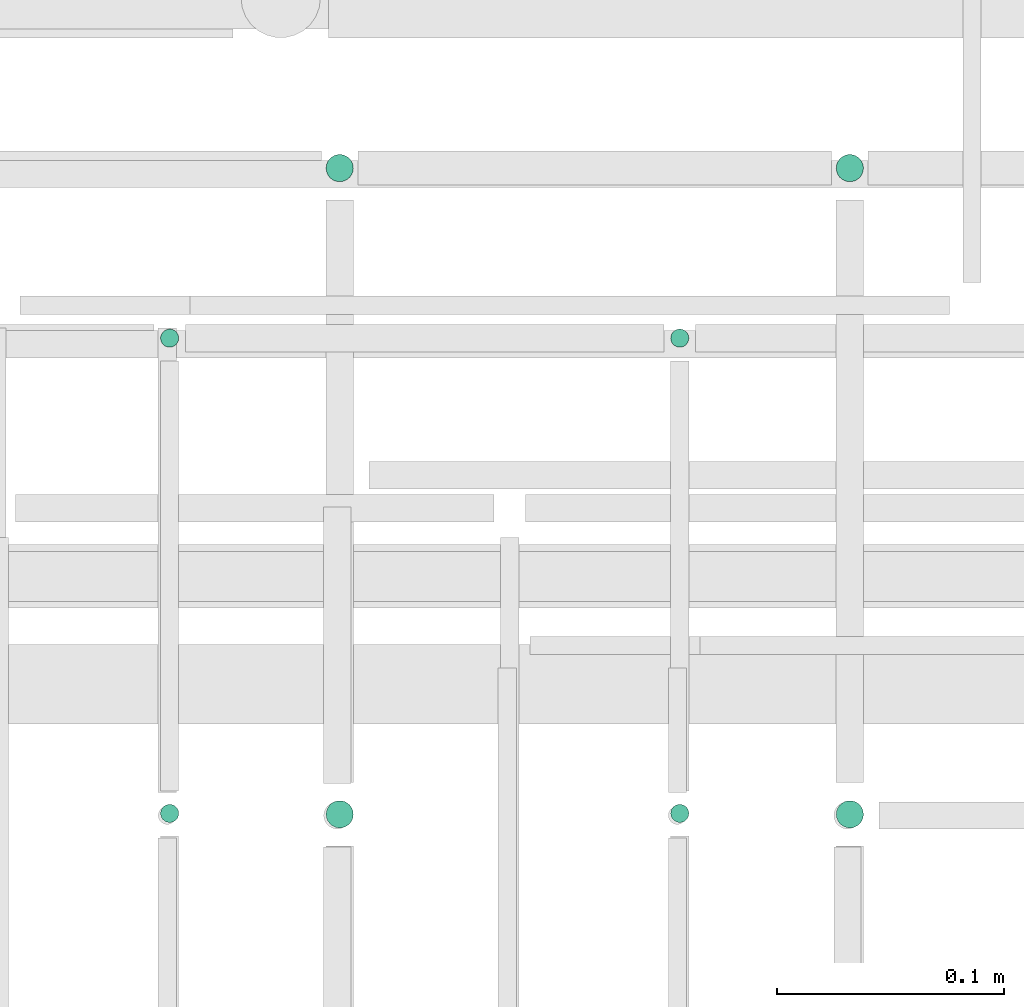
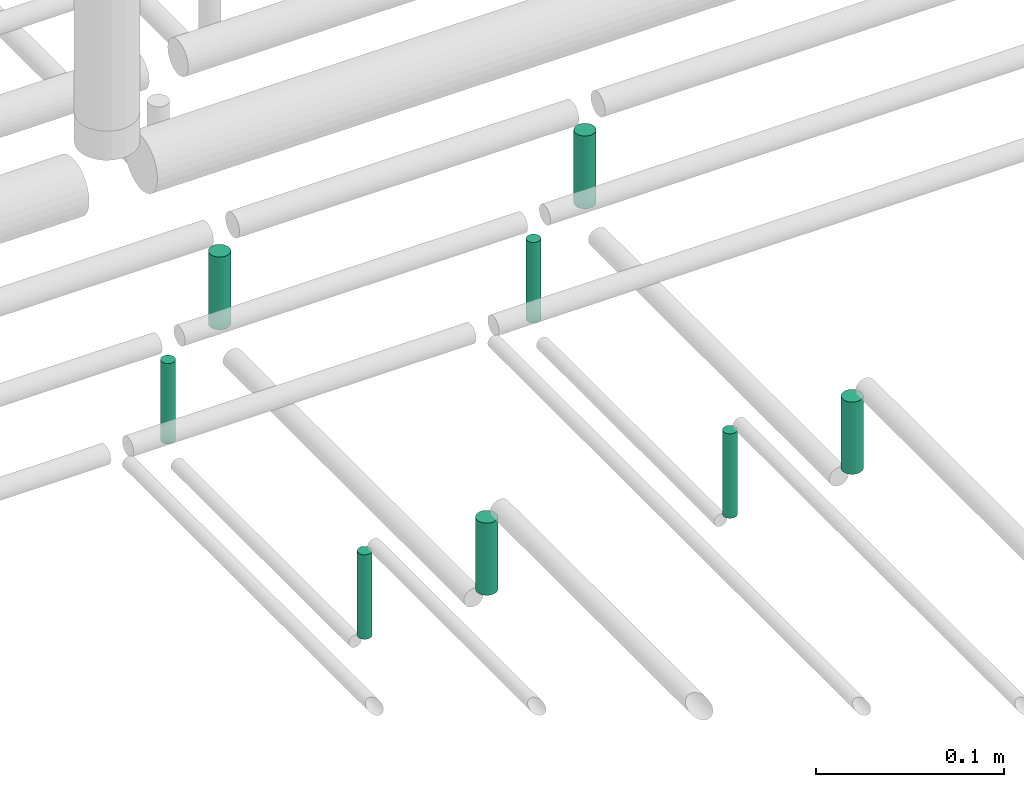
# One storey, part 293 of 331: 8 flow segments.
"""IFC2X3 building model written with IfcOpenShell, lengths in millimetres."""

from ifc_helpers import new_model, entity, si_unit, converted_unit, derived_unit, direction, frame, frame_2d, origin, origin_2d_with_axis, place, context, subcontext, project, spatial, circle, extrude, type_object, element, save


model = new_model("IFC2X3")

# Units and contexts
model_context = context("Model", 3, precision=0.01, world=origin(), true_north=direction((6.12303176911189e-17, 1.0)))
body_context = subcontext(model_context, "Body", "Model", "MODEL_VIEW")
ifc_project = project(units=[si_unit("LENGTHUNIT", "METRE", prefix="MILLI"), si_unit("AREAUNIT", "SQUARE_METRE"), si_unit("VOLUMEUNIT", "CUBIC_METRE"), converted_unit("PLANEANGLEUNIT", "DEGREE", entity("IfcRatioMeasure", 0.0174532925199433), si_unit("PLANEANGLEUNIT", "RADIAN"), dimensions=[0, 0, 0, 0, 0, 0, 0]), si_unit("MASSUNIT", "GRAM", prefix="KILO"), derived_unit("MASSDENSITYUNIT", [(si_unit("MASSUNIT", "GRAM", prefix="KILO"), 1), (si_unit("LENGTHUNIT", "METRE"), -3)]), derived_unit("MOMENTOFINERTIAUNIT", [(si_unit("LENGTHUNIT", "METRE"), 4)]), si_unit("TIMEUNIT", "SECOND"), si_unit("FREQUENCYUNIT", "HERTZ"), si_unit("THERMODYNAMICTEMPERATUREUNIT", "DEGREE_CELSIUS"), derived_unit("THERMALTRANSMITTANCEUNIT", [(si_unit("MASSUNIT", "GRAM", prefix="KILO"), 1), (si_unit("THERMODYNAMICTEMPERATUREUNIT", "KELVIN"), -1), (si_unit("TIMEUNIT", "SECOND"), -3)]), derived_unit("VOLUMETRICFLOWRATEUNIT", [(si_unit("LENGTHUNIT", "METRE"), 3), (si_unit("TIMEUNIT", "SECOND"), -1)]), derived_unit("MASSFLOWRATEUNIT", [(si_unit("MASSUNIT", "GRAM", prefix="KILO"), 1), (si_unit("TIMEUNIT", "SECOND"), -1)]), derived_unit("ROTATIONALFREQUENCYUNIT", [(si_unit("TIMEUNIT", "SECOND"), -1)]), si_unit("ELECTRICCURRENTUNIT", "AMPERE"), si_unit("ELECTRICVOLTAGEUNIT", "VOLT"), si_unit("POWERUNIT", "WATT"), si_unit("FORCEUNIT", "NEWTON", prefix="KILO"), si_unit("ILLUMINANCEUNIT", "LUX"), si_unit("LUMINOUSFLUXUNIT", "LUMEN"), si_unit("LUMINOUSINTENSITYUNIT", "CANDELA"), derived_unit("USERDEFINED", [(si_unit("MASSUNIT", "GRAM", prefix="KILO"), -1), (si_unit("LENGTHUNIT", "METRE"), -2), (si_unit("TIMEUNIT", "SECOND"), 3), (si_unit("LUMINOUSFLUXUNIT", "LUMEN"), 1)]), derived_unit("LINEARVELOCITYUNIT", [(si_unit("LENGTHUNIT", "METRE"), 1), (si_unit("TIMEUNIT", "SECOND"), -1)]), si_unit("PRESSUREUNIT", "PASCAL"), derived_unit("USERDEFINED", [(si_unit("LENGTHUNIT", "METRE"), -2), (si_unit("MASSUNIT", "GRAM", prefix="KILO"), 1), (si_unit("TIMEUNIT", "SECOND"), -2)]), derived_unit("LINEARFORCEUNIT", [(si_unit("MASSUNIT", "GRAM", prefix="KILO"), 1), (si_unit("LENGTHUNIT", "METRE"), 1), (si_unit("TIMEUNIT", "SECOND"), -2), (si_unit("LENGTHUNIT", "METRE"), -1)]), derived_unit("PLANARFORCEUNIT", [(si_unit("MASSUNIT", "GRAM", prefix="KILO"), 1), (si_unit("LENGTHUNIT", "METRE"), 1), (si_unit("TIMEUNIT", "SECOND"), -2), (si_unit("LENGTHUNIT", "METRE"), -2)])], contexts=[model_context])

# Site, building, storey
site_placement = place(None, frame((0.0, -0.00077364408347762, 0.0)))
site = spatial("IfcSite", under=ifc_project, at=site_placement, CompositionType="ELEMENT")
building_placement = place(site_placement, origin())
building = spatial("IfcBuilding", under=site, at=building_placement, CompositionType="ELEMENT")
storey_placement = place(building_placement, origin())
storey = spatial("IfcBuildingStorey", under=building, at=storey_placement, CompositionType="ELEMENT", Elevation=0.0)

# Flow segments
pipe_segment_type = type_object("IfcPipeSegmentType", PredefinedType="NOTDEFINED")
flow_segment_1_placement = place(storey_placement, frame((62165.5225183915, 8085.4146716134, 14485.0)))
element("IfcFlowSegment", 1, at=flow_segment_1_placement, inside=storey, type_object=pipe_segment_type, context=body_context, shape_type="SweptSolid", body=[
    extrude(circle(Radius=4.0, at=frame_2d((0.0, 1.08286712929839e-12), x_axis=(1.0, 0.0))), frame((5.59527223591499, 5.59527223591716, 0.0), z_axis=(0.0, 0.0, 1.0), x_axis=(-1.0, 0.0, 0.0)), (0.0, 0.0, 1.0), 55.0000000000243),
])
flow_segment_2_placement = place(storey_placement, frame((61940.5225183915, 8085.4146716134, 14485.0)))
element("IfcFlowSegment", 2, at=flow_segment_2_placement, inside=storey, type_object=pipe_segment_type, context=body_context, shape_type="SweptSolid", body=[
    extrude(circle(Radius=4.0, at=frame_2d((0.0, 1.08286712929839e-12), x_axis=(1.0, 0.0))), frame((5.59527223591499, 5.59527223591716, 0.0), z_axis=(0.0, 0.0, 1.0), x_axis=(-1.0, 0.0, 0.0)), (0.0, 0.0, 1.0), 55.0000000000178),
])
flow_segment_3_placement = place(storey_placement, frame((62238.5225183915, 8368.02529159144, 14489.0)))
element("IfcFlowSegment", 3, at=flow_segment_3_placement, inside=storey, type_object=pipe_segment_type, context=body_context, shape_type="SweptSolid", body=[
    extrude(circle(Radius=6.0, at=frame_2d((0.0, -1.08286712929839e-12), x_axis=(1.0, 0.0))), frame((7.59527223591454, 7.5952722359167, 0.0)), (0.0, 0.0, 1.0), 47.3874126245895),
])
flow_segment_4_placement = place(storey_placement, frame((62238.5225183915, 8083.02529159146, 14489.0)))
element("IfcFlowSegment", 4, at=flow_segment_4_placement, inside=storey, type_object=pipe_segment_type, context=body_context, shape_type="SweptSolid", body=[
    extrude(circle(Radius=6.0, at=frame_2d((0.0, -1.08286712929839e-12), x_axis=(1.0, 0.0))), frame((7.59527223591454, 7.59527223591454, 0.0), z_axis=(0.0, 0.0, 1.0), x_axis=(-1.0, 0.0, 0.0)), (0.0, 0.0, 1.0), 47.0000000000066),
])
flow_segment_5_placement = place(storey_placement, frame((62013.5225183915, 8083.02529159144, 14489.0)))
element("IfcFlowSegment", 5, at=flow_segment_5_placement, inside=storey, type_object=pipe_segment_type, context=body_context, shape_type="SweptSolid", body=[
    extrude(circle(Radius=6.0, at=origin_2d_with_axis()), frame((7.59527223591454, 7.59527223591562, 0.0), z_axis=(0.0, 0.0, 1.0), x_axis=(-1.0, 0.0, 0.0)), (0.0, 0.0, 1.0), 47.000000000024),
])
flow_segment_6_placement = place(storey_placement, frame((62165.5214460933, 8295.02529159145, 14484.9999156955)))
element("IfcFlowSegment", 6, at=flow_segment_6_placement, inside=storey, type_object=pipe_segment_type, context=body_context, shape_type="SweptSolid", body=[
    extrude(circle(Radius=4.0, at=origin_2d_with_axis()), frame((5.59637589690863, 5.59527223591607, 8.43044372913937e-05)), (0.0, 0.0, 1.0), 52.3655418843274),
])
flow_segment_7_placement = place(storey_placement, frame((61940.5214461943, 8295.02529159145, 14484.9999156955)))
element("IfcFlowSegment", 7, at=flow_segment_7_placement, inside=storey, type_object=pipe_segment_type, context=body_context, shape_type="SweptSolid", body=[
    extrude(circle(Radius=4.0, at=origin_2d_with_axis()), frame((5.59637579696432, 5.59527223591607, 8.43044372913937e-05)), (0.0, 0.0, 1.0), 52.3607997597633),
])
flow_segment_8_placement = place(storey_placement, frame((62013.5215043894, 8368.02529159144, 14488.9998651561)))
element("IfcFlowSegment", 8, at=flow_segment_8_placement, inside=storey, type_object=pipe_segment_type, context=body_context, shape_type="SweptSolid", body=[
    extrude(circle(Radius=6.0, at=frame_2d((-4.86726227662116e-17, 1.08286712929839e-12), x_axis=(1.0, 0.0))), frame((7.59633722971546, 7.59527223591454, 0.000134843756393366)), (0.0, 0.0, 1.0), 47.3879711437763),
])

save(model, "model.ifc")
